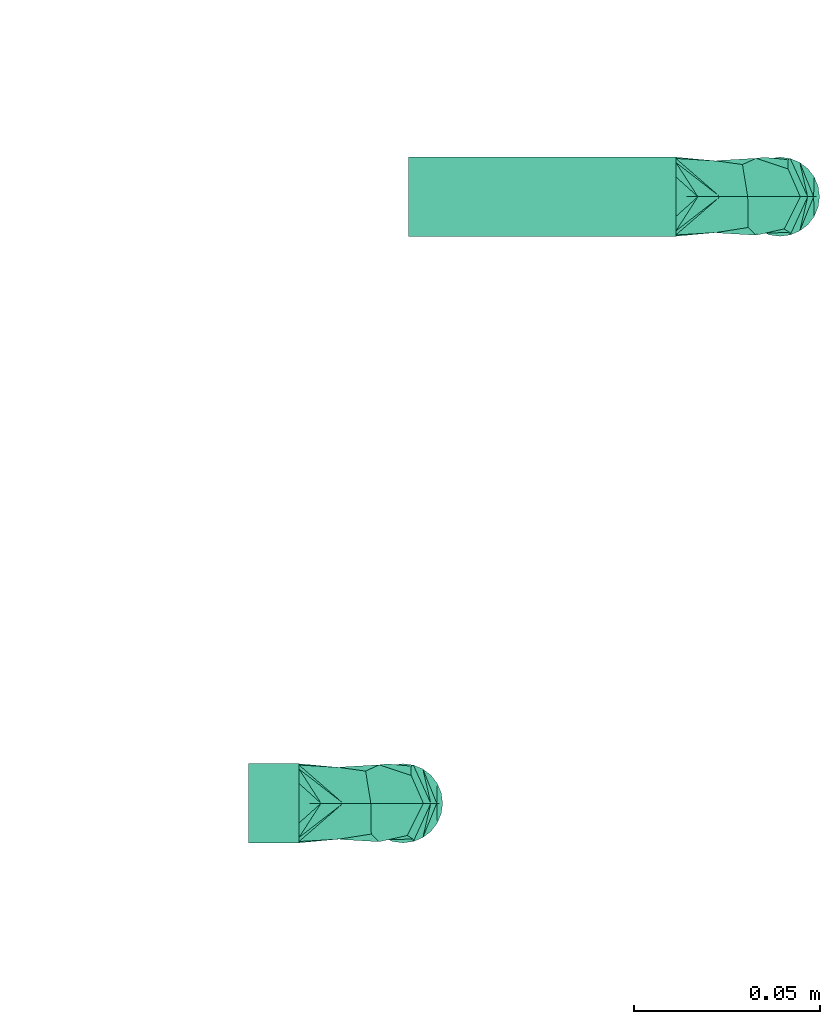
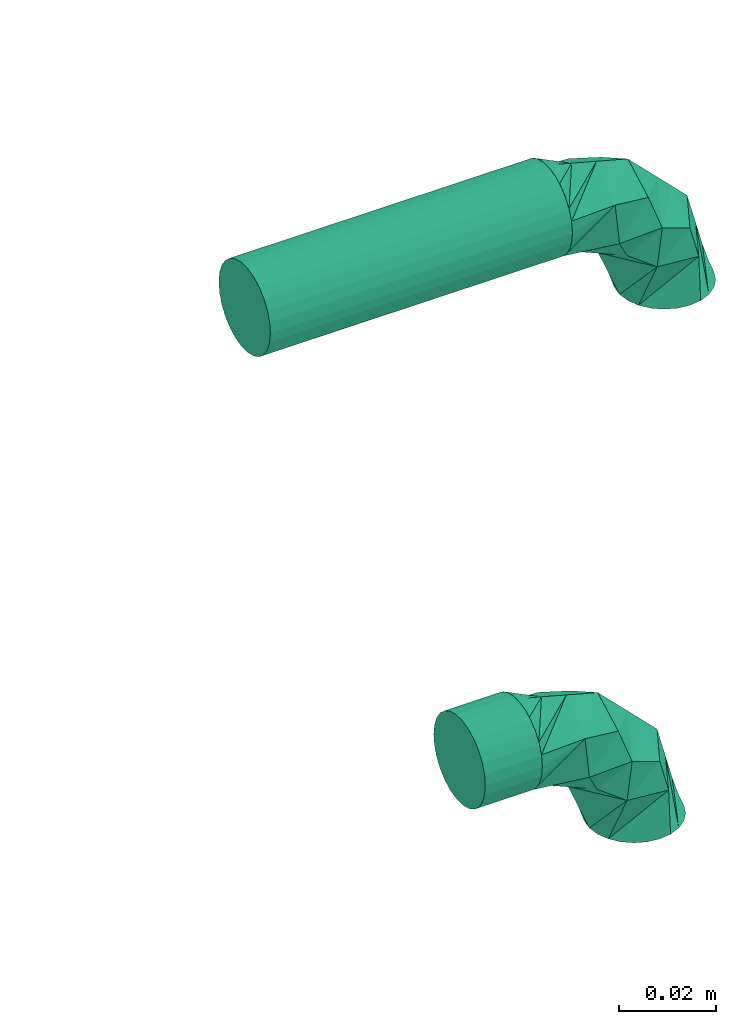
# One storey, part 780 of 827: 2 flow fittings, 2 flow segments.
"""IFC2X3 building model written with IfcOpenShell, lengths in millimetres."""

from ifc_helpers import new_model, entity, si_unit, converted_unit, derived_unit, direction, frame, origin, origin_2d_with_axis, place, context, subcontext, project, spatial, circle, extrude, faceted_brep, source, transform, mapped, material, type_object, type_shapes, element, save


model = new_model("IFC2X3")

# Units and contexts
model_context = context("Model", 3, precision=0.01, world=origin(), true_north=direction((6.12303176911189e-17, 1.0)))
body_context = subcontext(model_context, "Body", "Model", "MODEL_VIEW")
ifc_project = project(units=[si_unit("LENGTHUNIT", "METRE", prefix="MILLI"), si_unit("AREAUNIT", "SQUARE_METRE"), si_unit("VOLUMEUNIT", "CUBIC_METRE"), converted_unit("PLANEANGLEUNIT", "DEGREE", entity("IfcRatioMeasure", 0.0174532925199433), si_unit("PLANEANGLEUNIT", "RADIAN"), dimensions=[0, 0, 0, 0, 0, 0, 0]), si_unit("MASSUNIT", "GRAM", prefix="KILO"), derived_unit("MASSDENSITYUNIT", [(si_unit("MASSUNIT", "GRAM", prefix="KILO"), 1), (si_unit("LENGTHUNIT", "METRE"), -3)]), derived_unit("MOMENTOFINERTIAUNIT", [(si_unit("LENGTHUNIT", "METRE"), 4)]), si_unit("TIMEUNIT", "SECOND"), si_unit("FREQUENCYUNIT", "HERTZ"), si_unit("THERMODYNAMICTEMPERATUREUNIT", "DEGREE_CELSIUS"), derived_unit("THERMALTRANSMITTANCEUNIT", [(si_unit("MASSUNIT", "GRAM", prefix="KILO"), 1), (si_unit("THERMODYNAMICTEMPERATUREUNIT", "KELVIN"), -1), (si_unit("TIMEUNIT", "SECOND"), -3)]), derived_unit("VOLUMETRICFLOWRATEUNIT", [(si_unit("LENGTHUNIT", "METRE"), 3), (si_unit("TIMEUNIT", "SECOND"), -1)]), derived_unit("MASSFLOWRATEUNIT", [(si_unit("MASSUNIT", "GRAM", prefix="KILO"), 1), (si_unit("TIMEUNIT", "SECOND"), -1)]), derived_unit("ROTATIONALFREQUENCYUNIT", [(si_unit("TIMEUNIT", "SECOND"), -1)]), si_unit("ELECTRICCURRENTUNIT", "AMPERE"), si_unit("ELECTRICVOLTAGEUNIT", "VOLT"), si_unit("POWERUNIT", "WATT"), si_unit("FORCEUNIT", "NEWTON", prefix="KILO"), si_unit("ILLUMINANCEUNIT", "LUX"), si_unit("LUMINOUSFLUXUNIT", "LUMEN"), si_unit("LUMINOUSINTENSITYUNIT", "CANDELA"), derived_unit("USERDEFINED", [(si_unit("MASSUNIT", "GRAM", prefix="KILO"), -1), (si_unit("LENGTHUNIT", "METRE"), -2), (si_unit("TIMEUNIT", "SECOND"), 3), (si_unit("LUMINOUSFLUXUNIT", "LUMEN"), 1)]), derived_unit("LINEARVELOCITYUNIT", [(si_unit("LENGTHUNIT", "METRE"), 1), (si_unit("TIMEUNIT", "SECOND"), -1)]), si_unit("PRESSUREUNIT", "PASCAL"), derived_unit("USERDEFINED", [(si_unit("LENGTHUNIT", "METRE"), -2), (si_unit("MASSUNIT", "GRAM", prefix="KILO"), 1), (si_unit("TIMEUNIT", "SECOND"), -2)]), derived_unit("LINEARFORCEUNIT", [(si_unit("MASSUNIT", "GRAM", prefix="KILO"), 1), (si_unit("LENGTHUNIT", "METRE"), 1), (si_unit("TIMEUNIT", "SECOND"), -2), (si_unit("LENGTHUNIT", "METRE"), -1)]), derived_unit("PLANARFORCEUNIT", [(si_unit("MASSUNIT", "GRAM", prefix="KILO"), 1), (si_unit("LENGTHUNIT", "METRE"), 1), (si_unit("TIMEUNIT", "SECOND"), -2), (si_unit("LENGTHUNIT", "METRE"), -2)])], contexts=[model_context])

# Site, building, storey
site_placement = place(None, origin())
site = spatial("IfcSite", under=ifc_project, at=site_placement, CompositionType="ELEMENT")
building_placement = place(site_placement, origin())
building = spatial("IfcBuilding", under=site, at=building_placement, CompositionType="ELEMENT")
storey_placement = place(building_placement, frame((0.0, 0.0, 28200.0)))
storey = spatial("IfcBuildingStorey", under=building, at=storey_placement, Name="08", CompositionType="ELEMENT", Elevation=28200.0)

# Flow segments
pipe_segment_type = type_object("IfcPipeSegmentType", PredefinedType="NOTDEFINED")
flow_segment_1_placement = place(storey_placement, frame((71927.11, 7958.79, 1707.75)))
element("IfcFlowSegment", 1, at=flow_segment_1_placement, inside=storey, type_object=pipe_segment_type, context=body_context, shape_type="SweptSolid", body=[
    extrude(circle(Radius=10.65, at=origin_2d_with_axis()), frame((0.0, 12.25, 12.25), z_axis=(1.0, 0.0, 0.0), x_axis=(0.0, 1.0, 0.0)), (0.0, 0.0, 1.0), 13.600167759999),
])
flow_segment_2_placement = place(storey_placement, frame((71970.11, 8121.98, 1707.75)))
element("IfcFlowSegment", 2, at=flow_segment_2_placement, inside=storey, type_object=pipe_segment_type, context=body_context, shape_type="SweptSolid", body=[
    extrude(circle(Radius=10.65, at=origin_2d_with_axis()), frame((0.0, 12.25, 12.25), z_axis=(1.0, 0.0, 0.0), x_axis=(0.0, 1.0, 0.0)), (0.0, 0.0, 1.0), 72.0000000000096),
])

# Flow fittings
ifc_material = material()
pipe_fitting_type = type_object("IfcPipeFittingType", Name="ADSK_1", PredefinedType="NOTDEFINED", material=ifc_material)
shared_shape = source(origin(), body_context, "Body", "Brep", [
    faceted_brep([(-28.0, 2.76, -10.29), (-28.0, 0.0, -10.65), (-28.0, -2.76, -10.29), (-28.0, -5.33, -9.22), (-28.0, -7.53, -7.53), (-28.0, -9.22, -5.33), (-28.0, -10.29, -2.76), (-28.0, -10.65, 0.0), (-28.0, -10.29, 2.76), (-28.0, -9.22, 5.32), (-28.0, -7.53, 7.53), (-28.0, -5.33, 9.22), (-28.0, -2.76, 10.29), (-28.0, 0.0, 10.65), (-28.0, 2.76, 10.29), (-28.0, 5.32, 9.22), (-28.0, 7.53, 7.53), (-28.0, 9.22, 5.32), (-28.0, 10.29, 2.76), (-28.0, 10.65, 0.0), (-28.0, 10.29, -2.76), (-28.0, 9.22, -5.33), (-28.0, 7.53, -7.53), (-28.0, 5.32, -9.22), (-7.53, 28.0, -7.53), (-9.22, 28.0, -5.33), (-10.29, 28.0, -2.76), (-10.65, 28.0, 0.0), (-10.29, 28.0, 2.76), (-9.22, 28.0, 5.32), (-7.53, 28.0, 7.53), (-5.32, 28.0, 9.22), (-2.76, 28.0, 10.29), (0.0, 28.0, 10.65), (2.76, 28.0, 10.29), (5.33, 28.0, 9.22), (7.53, 28.0, 7.53), (9.22, 28.0, 5.32), (10.29, 28.0, 2.76), (10.65, 28.0, 0.0), (10.29, 28.0, -2.76), (9.22, 28.0, -5.33), (7.53, 28.0, -7.53), (5.33, 28.0, -9.22), (2.76, 28.0, -10.29), (0.0, 28.0, -10.65), (-2.76, 28.0, -10.29), (-5.32, 28.0, -9.22), (-25.03, -9.85, 0.0), (-17.25, -2.67, 9.65), (-16.12, -7.47, 0.0), (-8.67, -5.47, 0.0), (2.67, 17.25, 9.65), (0.73, 8.55, 8.28), (5.47, 8.67, 0.0), (-1.6, 1.6, 0.0), (-6.42, 6.42, 10.35), (-22.06, -9.06, 0.0), (-5.14, -1.94, 0.0), (-13.19, 21.87, 0.0), (-12.06, 13.7, 8.37), (-7.31, 16.28, 9.78), (1.94, 5.14, 0.0), (-10.08, -1.14, 8.66), (-16.28, 7.31, 9.78), (-15.73, 15.73, 0.0), (-21.87, 13.19, 0.0), (7.47, 16.12, 0.0), (9.06, 22.06, 0.0), (9.85, 25.03, 0.0), (-18.32, -2.2, -9.98), (2.67, 17.25, -9.65), (-7.31, 16.28, -9.78), (-6.45, 6.38, -10.35), (-14.91, 4.23, -10.61), (-12.05, 13.69, -8.38), (1.14, 10.08, -8.66), (-9.15, -2.2, -7.46)], [[[0, 1, 2, 3, 4, 5, 6, 7, 8, 9, 10, 11, 12, 13, 14, 15, 16, 17, 18, 19, 20, 21, 22, 23]], [[24, 25, 26, 27, 28, 29, 30, 31, 32, 33, 34, 35, 36, 37, 38, 39, 40, 41, 42, 43, 44, 45, 46, 47]], [[8, 48, 9]], [[49, 50, 51]], [[52, 53, 54]], [[55, 53, 56]], [[11, 10, 57]], [[9, 57, 10]], [[56, 58, 55]], [[11, 50, 12]], [[12, 50, 49]], [[59, 60, 61]], [[53, 55, 62, 54]], [[63, 51, 58]], [[12, 49, 13]], [[14, 13, 49]], [[60, 64, 56]], [[63, 49, 51]], [[8, 7, 48]], [[49, 16, 15]], [[48, 57, 9]], [[19, 18, 64]], [[17, 16, 49]], [[17, 64, 18]], [[49, 15, 14]], [[30, 52, 31]], [[64, 65, 66, 19]], [[33, 52, 34]], [[67, 35, 34]], [[49, 64, 17]], [[32, 52, 33]], [[36, 35, 68]], [[56, 63, 58]], [[68, 35, 67]], [[38, 69, 39]], [[49, 63, 64]], [[53, 52, 61]], [[11, 57, 50]], [[27, 61, 28]], [[56, 61, 60]], [[61, 27, 59]], [[68, 37, 36]], [[29, 28, 61]], [[53, 61, 56]], [[52, 32, 31]], [[37, 69, 38]], [[52, 29, 61]], [[68, 69, 37]], [[30, 29, 52]], [[67, 34, 52]], [[52, 54, 67]], [[64, 60, 65]], [[63, 56, 64]], [[65, 60, 59]], [[23, 70, 0]], [[71, 72, 25]], [[73, 62, 55, 58]], [[22, 70, 23]], [[51, 50, 70]], [[57, 48, 5]], [[74, 70, 21]], [[5, 48, 6]], [[74, 21, 20]], [[75, 72, 73]], [[72, 71, 76]], [[70, 22, 21]], [[48, 7, 6]], [[3, 57, 4]], [[70, 2, 1]], [[66, 75, 74]], [[57, 3, 50]], [[3, 2, 50]], [[70, 1, 0]], [[27, 72, 59]], [[59, 75, 65]], [[58, 77, 73]], [[20, 19, 66]], [[74, 75, 73]], [[27, 26, 72]], [[76, 62, 73]], [[43, 68, 67]], [[75, 59, 72]], [[24, 71, 25]], [[57, 5, 4]], [[47, 46, 71]], [[69, 68, 41]], [[40, 39, 69]], [[47, 71, 24]], [[65, 75, 66]], [[45, 71, 46]], [[67, 71, 44]], [[25, 72, 26]], [[42, 68, 43]], [[67, 44, 43]], [[76, 71, 54]], [[45, 44, 71]], [[41, 40, 69]], [[54, 71, 67]], [[70, 77, 51]], [[73, 77, 74]], [[41, 68, 42]], [[70, 50, 2]], [[74, 77, 70]], [[76, 54, 62]], [[76, 73, 72]], [[20, 66, 74]], [[77, 58, 51]]]),
])
type_shapes(pipe_fitting_type, [shared_shape])
for number, where, z_axis, x_axis, name in (
    (3, (71968.71, 7971.04, 1720.0), (0.0, -1.0, 0.0), (0.0, 0.0, 1.0), "ADSK_1"),
    (4, (72070.11, 8134.23, 1720.0), (0.0, -1.0, 0.0), (0.0, 0.0, 1.0), "ADSK_1"),
):
    element("IfcFlowFitting", number, at=place(storey_placement, frame(where, z_axis=z_axis, x_axis=x_axis)), inside=storey, type_object=pipe_fitting_type, material=ifc_material, Name=name, ObjectType="ADSK_1", context=body_context, shape_type="MappedRepresentation", body=[
        mapped(shared_shape, transform((0.0, 0.0, 0.0), scale=1.0)),
    ])

save(model, "model.ifc")
